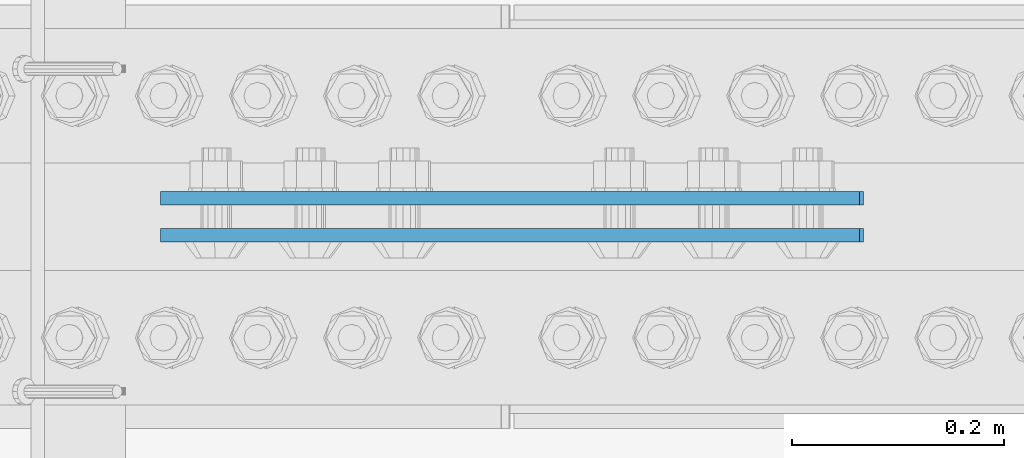
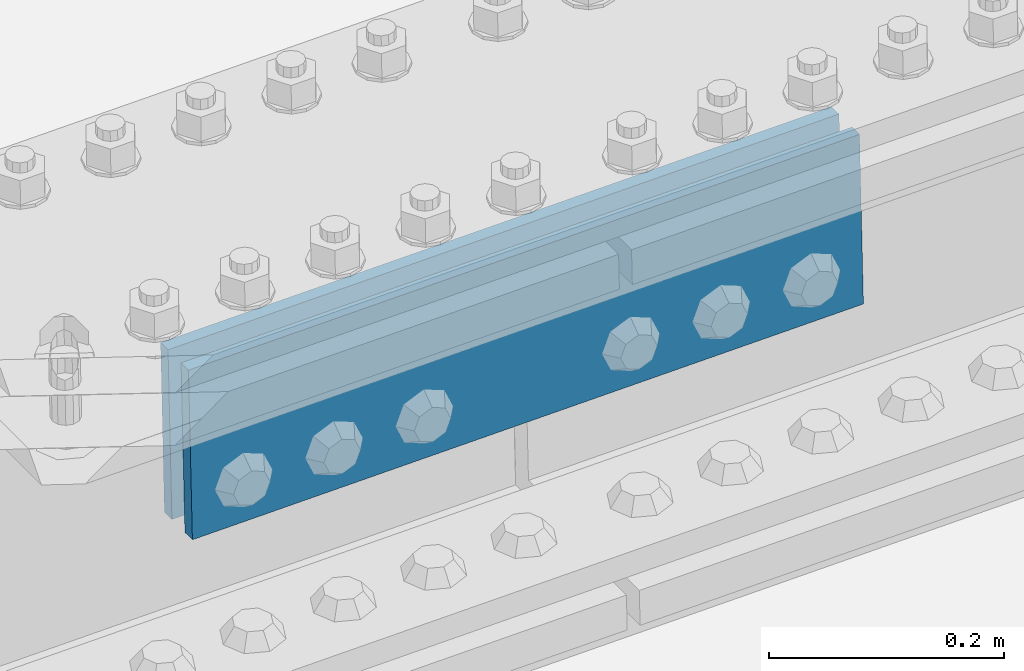
# One storey, part 2282 of 3843: 2 beams, 1 element without a shape of its own.
"""IFC2X3 building model written with IfcOpenShell, lengths in millimetres."""

from ifc_helpers import new_model, si_unit, frame, origin_with_axes, place, context, subcontext, project, spatial, faceted_brep, material, type_object, element, aggregate, save


model = new_model("IFC2X3")

# Units and contexts
model_context = context("Model", 3, precision=1e-05, world=origin_with_axes())
body_context = subcontext(model_context, "Body", "Model", "MODEL_VIEW")
ifc_project = project(units=[si_unit("LENGTHUNIT", "METRE", prefix="MILLI"), si_unit("AREAUNIT", "SQUARE_METRE"), si_unit("VOLUMEUNIT", "CUBIC_METRE"), si_unit("MASSUNIT", "GRAM", prefix="KILO"), si_unit("TIMEUNIT", "SECOND"), si_unit("PLANEANGLEUNIT", "RADIAN"), si_unit("SOLIDANGLEUNIT", "STERADIAN"), si_unit("THERMODYNAMICTEMPERATUREUNIT", "DEGREE_CELSIUS"), si_unit("LUMINOUSINTENSITYUNIT", "LUMEN")], contexts=[model_context])

# Site, building, storey
site_placement = place(None, origin_with_axes())
site = spatial("IfcSite", under=ifc_project, at=site_placement, CompositionType="ELEMENT")
building_placement = place(site_placement, origin_with_axes())
building = spatial("IfcBuilding", under=site, at=building_placement, Name="Undefined", CompositionType="ELEMENT")
storey_placement = place(building_placement, origin_with_axes())
storey = spatial("IfcBuildingStorey", under=building, at=storey_placement, Name="Undefined", CompositionType="ELEMENT", Elevation=0.0)

# Assembly, beams
assembly_placement = place(storey_placement, origin_with_axes())
assembly = element("IfcElementAssembly", 1, at=assembly_placement, inside=storey, Name="BEAM", AssemblyPlace="NOTDEFINED", PredefinedType="RIGID_FRAME")
ifc_material = material(Name="STEEL/A572-50")
beam_type = type_object("IfcBeamType", PredefinedType="NOTDEFINED")
beam_1_placement = place(assembly_placement, frame((65840.9531780021, 42219.5625, 45921.2446722696), z_axis=(0.0214841639937949, 0.0, -0.999769188711819), x_axis=(-0.999769188711818, 0.0, -0.0214841639938015)))
beam_1 = element("IfcBeam", 2, at=beam_1_placement, type_object=beam_type, material=ifc_material, Name="PLATE", context=body_context, shape_type="Brep", body=[
    faceted_brep([(1.45519152283669e-11, 6.35000000000582, -88.8999999998996), (0.0, 6.34999999999854, 88.9000015258789), (660.399999982677, 6.35000000000582, 88.8999999999651), (660.399999982707, 6.35000000000582, -88.8999999998268), (0.0, -6.34999999999854, 88.9000015258789), (660.399999982677, -6.35000000000582, 88.8999999999651), (1.45519152283669e-11, -6.35000000000582, -88.8999999998996), (660.399999982707, -6.35000000000582, -88.8999999998268)], [[[0, 1, 2, 3]], [[1, 4, 5, 2]], [[4, 6, 7, 5]], [[6, 0, 3, 7]], [[5, 7, 3, 2]], [[6, 4, 1, 0]]]),
])
beam_2_placement = place(assembly_placement, frame((65840.9531780021, 42184.6375, 45921.2446722696), z_axis=(0.0214841639937949, 0.0, -0.999769188711819), x_axis=(-0.999769188711818, 0.0, -0.0214841639938015)))
beam_2 = element("IfcBeam", 3, at=beam_2_placement, type_object=beam_type, material=ifc_material, Name="PLATE", context=body_context, shape_type="Brep", body=[
    faceted_brep([(1.45519152283669e-11, 6.35000000000582, -88.8999999998996), (0.0, 6.34999999999854, 88.9000015258789), (660.399999982677, 6.35000000000582, 88.8999999999651), (660.399999982707, 6.35000000000582, -88.8999999998268), (0.0, -6.34999999999854, 88.9000015258789), (660.399999982677, -6.35000000000582, 88.8999999999651), (1.45519152283669e-11, -6.35000000000582, -88.8999999998996), (660.399999982707, -6.35000000000582, -88.8999999998268)], [[[0, 1, 2, 3]], [[1, 4, 5, 2]], [[4, 6, 7, 5]], [[6, 0, 3, 7]], [[5, 7, 3, 2]], [[6, 4, 1, 0]]]),
])
aggregate(assembly, [beam_1, beam_2])

save(model, "model.ifc")
